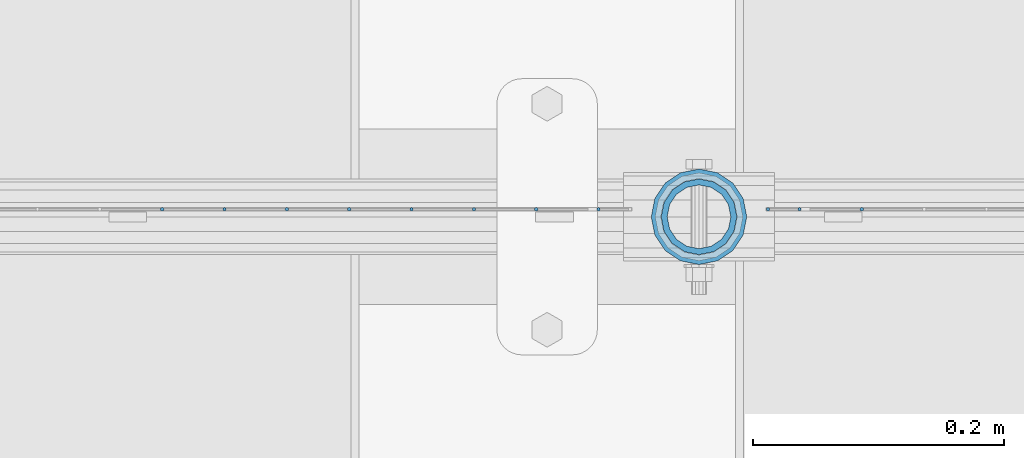
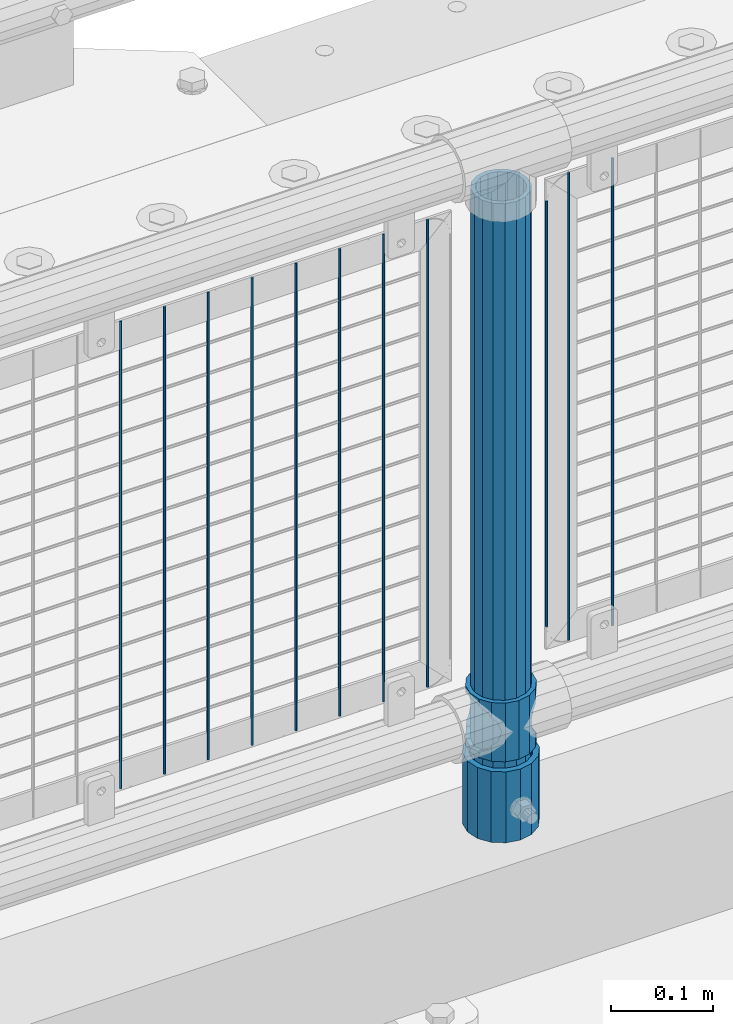
# One storey, part 74 of 247: 14 columns.
"""IFC2X3 building model written with IfcOpenShell, lengths in millimetres."""

from ifc_helpers import new_model, si_unit, frame, origin_with_axes, place, context, subcontext, project, spatial, faceted_brep, material, type_object, element, save


model = new_model("IFC2X3")

# Units and contexts
model_context = context("Model", 3, precision=1e-05, world=origin_with_axes())
body_context = subcontext(model_context, "Body", "Model", "MODEL_VIEW")
ifc_project = project(units=[si_unit("LENGTHUNIT", "METRE", prefix="MILLI"), si_unit("AREAUNIT", "SQUARE_METRE"), si_unit("VOLUMEUNIT", "CUBIC_METRE"), si_unit("MASSUNIT", "GRAM", prefix="KILO"), si_unit("TIMEUNIT", "SECOND"), si_unit("PLANEANGLEUNIT", "RADIAN"), si_unit("SOLIDANGLEUNIT", "STERADIAN"), si_unit("THERMODYNAMICTEMPERATUREUNIT", "DEGREE_CELSIUS"), si_unit("LUMINOUSINTENSITYUNIT", "LUMEN")], contexts=[model_context])

# Site, building, storey
site_placement = place(None, origin_with_axes())
site = spatial("IfcSite", under=ifc_project, at=site_placement, CompositionType="ELEMENT")
building_placement = place(site_placement, origin_with_axes())
building = spatial("IfcBuilding", under=site, at=building_placement, Name="Standard", CompositionType="ELEMENT")
storey_placement = place(building_placement, origin_with_axes())
storey = spatial("IfcBuildingStorey", under=building, at=storey_placement, Name="Undefined", CompositionType="ELEMENT", Elevation=0.0)

# Columns
ifc_material_1 = material()
column_type_1 = type_object("IfcColumnType", PredefinedType="NOTDEFINED")
column_1_placement = place(storey_placement, frame((3821.0, 7664.5, 168.02), z_axis=(0.0, 1.0, 0.0), x_axis=(0.0, 0.0, 1.0)))
element("IfcColumn", 1, at=column_1_placement, inside=storey, type_object=column_type_1, material=ifc_material_1, context=body_context, shape_type="Brep", body=[
    faceted_brep([(0.0, -31.75, 0.0), (0.0, -29.3331751572332, 12.1501989775916), (85.0, -29.3331751572332, 12.1501989775916), (85.0, -31.75, 0.0), (0.0, -22.4506403026735, 22.4506403026726), (85.0, -22.4506403026735, 22.4506403026726), (0.0, -12.1501989775916, 29.3331751572332), (85.0, -12.1501989775916, 29.3331751572332), (0.0, 0.0, 31.75), (85.0, 0.0, 31.75), (0.0, 12.1501989775916, 29.3331751572332), (85.0, 12.1501989775916, 29.3331751572332), (0.0, 22.4506403026735, 22.4506403026726), (85.0, 22.4506403026735, 22.4506403026726), (0.0, 29.3331751572332, 12.1501989775916), (85.0, 29.3331751572332, 12.1501989775916), (0.0, 31.75, 0.0), (85.0, 31.75, 0.0), (0.0, 29.3331751572332, -12.1501989775916), (85.0, 29.3331751572332, -12.1501989775916), (0.0, 22.4506403026735, -22.4506403026726), (85.0, 22.4506403026735, -22.4506403026726), (0.0, 12.1501989775916, -29.3331751572332), (85.0, 12.1501989775916, -29.3331751572332), (0.0, 0.0, -31.75), (85.0, 0.0, -31.75), (0.0, -12.1501989775916, -29.3331751572332), (85.0, -12.1501989775916, -29.3331751572332), (0.0, -22.4506403026735, -22.4506403026726), (85.0, -22.4506403026735, -22.4506403026726), (0.0, -29.3331751572332, -12.1501989775916), (85.0, -29.3331751572332, -12.1501989775916), (0.0, -38.0499999999993, 0.0), (0.0, -35.1536162120537, -14.5611046014919), (85.0, -35.1536162120537, -14.5611046014919), (85.0, -38.0499999999993, 0.0), (0.0, -26.9054130241475, -26.9054130241484), (85.0, -26.9054130241475, -26.9054130241484), (0.0, -14.561104601491, -35.1536162120547), (85.0, -14.561104601491, -35.1536162120547), (0.0, 0.0, -38.0500000000002), (85.0, 0.0, -38.0500000000002), (0.0, 14.561104601491, -35.1536162120547), (85.0, 14.561104601491, -35.1536162120547), (0.0, 26.9054130241475, -26.9054130241484), (85.0, 26.9054130241475, -26.9054130241484), (0.0, 35.1536162120537, -14.5611046014919), (85.0, 35.1536162120537, -14.5611046014919), (0.0, 38.0499999999993, 0.0), (85.0, 38.0499999999993, 0.0), (0.0, 35.1536162120537, 14.5611046014919), (85.0, 35.1536162120537, 14.5611046014919), (0.0, 26.9054130241475, 26.9054130241484), (85.0, 26.9054130241475, 26.9054130241484), (0.0, 14.561104601491, 35.1536162120547), (85.0, 14.561104601491, 35.1536162120547), (0.0, 0.0, 38.0500000000002), (85.0, 0.0, 38.0500000000002), (0.0, -14.561104601491, 35.1536162120547), (85.0, -14.561104601491, 35.1536162120547), (0.0, -26.9054130241475, 26.9054130241484), (85.0, -26.9054130241475, 26.9054130241484), (0.0, -35.1536162120537, 14.5611046014919), (85.0, -35.1536162120537, 14.5611046014919)], [[[0, 1, 2, 3]], [[1, 4, 5, 2]], [[4, 6, 7, 5]], [[6, 8, 9, 7]], [[8, 10, 11, 9]], [[10, 12, 13, 11]], [[12, 14, 15, 13]], [[14, 16, 17, 15]], [[16, 18, 19, 17]], [[18, 20, 21, 19]], [[20, 22, 23, 21]], [[22, 24, 25, 23]], [[24, 26, 27, 25]], [[26, 28, 29, 27]], [[28, 30, 31, 29]], [[30, 0, 3, 31]], [[32, 33, 34, 35]], [[33, 36, 37, 34]], [[36, 38, 39, 37]], [[38, 40, 41, 39]], [[40, 42, 43, 41]], [[42, 44, 45, 43]], [[44, 46, 47, 45]], [[46, 48, 49, 47]], [[48, 50, 51, 49]], [[50, 52, 53, 51]], [[52, 54, 55, 53]], [[54, 56, 57, 55]], [[56, 58, 59, 57]], [[58, 60, 61, 59]], [[60, 62, 63, 61]], [[62, 32, 35, 63]], [[37, 39, 41, 43, 45, 47, 49, 51, 53, 55, 57, 59, 61, 63, 35, 34], [5, 7, 9, 11, 13, 15, 17, 19, 21, 23, 25, 27, 29, 31, 3, 2]], [[62, 60, 58, 56, 54, 52, 50, 48, 46, 44, 42, 40, 38, 36, 33, 32], [30, 28, 26, 24, 22, 20, 18, 16, 14, 12, 10, 8, 6, 4, 1, 0]]]),
])
ifc_material_2 = material(Name="Misc_Undefined")
column_type_2 = type_object("IfcColumnType", PredefinedType="NOTDEFINED")
column_2_placement = place(storey_placement, frame((3821.0, 7664.5, 263.02), z_axis=(-1.0, 0.0, 0.0), x_axis=(0.0, 0.0, 1.0)))
element("IfcColumn", 2, at=column_2_placement, inside=storey, type_object=column_type_2, material=ifc_material_2, context=body_context, shape_type="Brep", body=[
    faceted_brep([(56.6106908090114, 21.4606908090118, -21.4606908090118), (56.6106908090114, 21.4606908090118, -27.1226768591096), (61.9623795176755, 13.4513226476329, -32.4743655677721), (63.1897438117172, 11.6144421722802, -32.839743811719), (63.1897438117172, 11.6144421722802, -28.0397438117179), (46.7644421722801, 28.0397438117179, -11.6144421722802), (46.7644421722801, 28.0397438117179, -20.088203122983), (51.5310424080055, 24.8548033587067, -24.8548033587067), (35.1499999999996, 30.35, 0.0), (35.1499999999996, 30.3500000000004, -16.6306603983649), (23.5355578277192, 28.0397438117179, -11.6144421722802), (23.5355578277192, 28.0397438117179, -20.088203122983), (13.6893091909879, 21.4606908090118, -21.4606908090118), (13.6893091909879, 21.4606908090118, -27.1226768591096), (18.768957591997, 24.8548033587067, -24.8548033587067), (7.11025618828211, 11.6144421722802, -28.0397438117179), (7.11025618828211, 11.6144421722802, -32.839743811719), (8.33762048232387, 13.4513226476329, -32.4743655677721), (4.79999999999961, 0.0, -30.3500000000004), (4.79999999999961, 0.0, -35.1499999999996), (7.11025618828211, -11.6144421722802, -28.0397438117179), (7.11025618828211, -11.6144421722802, -32.839743811719), (13.6893091909879, -21.4606908090118, -21.4606908090118), (13.6893091909879, -21.4606908090118, -27.1226768591077), (8.33762048232325, -13.4513226476329, -32.4743655677721), (23.5355578277191, -28.0397438117179, -11.6144421722802), (23.5355578277191, -28.0397438117179, -20.0882031229885), (18.768957591997, -24.8548033587067, -24.8548033587067), (35.1499999999996, -30.35, 0.0), (35.1499999999996, -30.3500000000004, -16.6306603983739), (46.7644421722801, -28.0397438117179, -11.6144421722802), (46.7644421722801, -28.0397438117179, -20.0882031229885), (56.6106908090114, -21.4606908090118, -21.4606908090118), (56.6106908090114, -21.4606908090118, -27.1226768591077), (51.5310424080038, -24.8548033587067, -24.8548033587067), (63.1897438117172, -11.6144421722802, -28.0397438117179), (63.1897438117172, -11.6144421722802, -32.839743811719), (61.9623795176754, -13.4513226476329, -32.4743655677721), (65.4999999999997, 0.0, -30.3500000000004), (65.4999999999997, 0.0, -35.1499999999996), (0.0, -28.0397438117179, -11.6144421722802), (0.0, -30.3500000000004, 0.0), (0.0, -21.4606908090118, -21.4606908090118), (0.0, -11.6144421722802, -28.0397438117179), (0.0, 0.0, -30.3500000000004), (0.0, 11.6144421722802, -28.0397438117179), (0.0, 21.4606908090118, -21.4606908090118), (0.0, 28.0397438117179, -11.6144421722802), (0.0, 30.3500000000004, 0.0), (0.0, 28.0397438117179, 11.6144421722802), (23.5355578277192, 28.0397438117179, 11.6144421722806), (0.0, 21.4606908090118, 21.4606908090118), (13.6893091909879, 21.4606908090118, 21.4606908090118), (0.0, 11.6144421722802, 28.0397438117179), (7.11025618828211, 11.6144421722802, 28.0397438117175), (0.0, 0.0, 30.3500000000004), (4.79999999999961, 0.0, 30.3499999999999), (0.0, -11.6144421722802, 28.0397438117179), (7.11025618828205, -11.6144421722802, 28.0397438117175), (0.0, -21.4606908090118, 21.4606908090118), (13.6893091909879, -21.4606908090118, 21.4606908090118), (0.0, -28.0397438117179, 11.6144421722802), (23.5355578277191, -28.0397438117179, 11.6144421722806), (0.0, -32.4743655677721, 13.4513226476338), (0.0, -35.1499999999996, 0.0), (70.2999999999993, -35.1499999999996, 0.0), (70.2999999999993, -32.4743655677721, 13.4513226476338), (0.0, 13.4513226476329, -32.4743655677721), (0.0, 24.8548033587067, -24.8548033587067), (0.0, 0.0, -35.1499999999996), (0.0, -13.4513226476329, -32.4743655677721), (0.0, -24.8548033587067, -24.8548033587067), (0.0, -24.8548033587067, 24.8548033587067), (0.0, -13.4513226476329, 32.4743655677721), (0.0, 0.0, 35.1499999999996), (0.0, 13.4513226476329, 32.4743655677721), (0.0, 24.8548033587067, 24.8548033587067), (0.0, 32.4743655677721, 13.4513226476338), (0.0, 35.1499999999996, 0.0), (0.0, 32.4743655677721, -13.4513226476338), (0.0, -32.4743655677721, -13.4513226476338), (70.2999999999993, 32.4743655677721, 13.4513226476338), (70.2999999999993, 35.1499999999996, 0.0), (70.2999999999993, 32.4743655677721, -13.4513226476338), (70.2999999999993, 24.8548033587067, -24.8548033587067), (70.2999999999993, 13.4513226476329, -32.4743655677721), (70.2999999999993, 0.0, -35.1499999999996), (70.2999999999993, -13.4513226476329, -32.4743655677721), (70.2999999999993, -24.8548033587067, -24.8548033587067), (70.2999999999993, -32.4743655677721, -13.4513226476338), (70.2999999999993, 28.0397438117179, 11.6144421722802), (70.2999999999993, 21.4606908090118, 21.4606908090118), (56.6106908090114, 21.4606908090118, 21.4606908090118), (46.7644421722801, 28.0397438117179, 11.6144421722806), (70.2999999999993, 11.6144421722802, 28.0397438117179), (63.1897438117172, 11.6144421722802, 28.0397438117175), (70.2999999999993, 0.0, 30.3500000000004), (65.4999999999997, 0.0, 30.3499999999999), (70.2999999999993, -11.6144421722802, 28.0397438117179), (63.1897438117172, -11.6144421722802, 28.0397438117175), (70.2999999999993, -21.4606908090118, 21.4606908090118), (56.6106908090114, -21.4606908090118, 21.4606908090118), (70.2999999999993, -28.0397438117179, 11.6144421722802), (46.7644421722801, -28.0397438117179, 11.6144421722806), (70.2999999999993, -11.6144421722802, -28.0397438117179), (70.2999999999993, 0.0, -30.3500000000004), (70.2999999999993, -21.4606908090118, -21.4606908090118), (70.2999999999993, -28.0397438117179, -11.6144421722802), (70.2999999999993, -30.3500000000004, 0.0), (70.2999999999993, 24.8548033587067, 24.8548033587067), (70.2999999999993, 13.4513226476329, 32.4743655677721), (70.2999999999993, 0.0, 35.1499999999996), (70.2999999999993, -13.4513226476329, 32.4743655677721), (70.2999999999993, -24.8548033587067, 24.8548033587067), (70.2999999999993, 30.3500000000004, 0.0), (70.2999999999993, 28.0397438117179, -11.6144421722802), (70.2999999999993, 21.4606908090118, -21.4606908090118), (70.2999999999993, 11.6144421722802, -28.0397438117179), (61.9623795176755, 13.4513226476329, 32.4743655677717), (51.5310424080043, 24.8548033587067, 24.8548033587072), (56.6106908090114, 21.4606908090118, 27.1226768591082), (65.4999999999997, 0.0, 35.1500000000001), (63.1897438117172, 11.6144421722802, 32.8397438117177), (63.1897438117172, -11.6144421722802, 32.8397438117177), (61.962379517675, -13.4513226476329, 32.4743655677717), (56.6106908090114, -21.4606908090118, 27.1226768591068), (51.5310424080026, -24.8548033587067, 24.8548033587072), (18.7689575919956, -24.8548033587067, 24.8548033587072), (46.7644421722801, -28.0397438117179, 20.088203122983), (35.1499999999996, -30.3500000000004, 16.6306603983649), (23.5355578277191, -28.0397438117179, 20.088203122983), (8.33762048232268, -13.4513226476329, 32.4743655677717), (13.6893091909879, -21.4606908090118, 27.1226768591068), (4.79999999999961, 0.0, 35.1500000000001), (7.11025618828205, -11.6144421722802, 32.8397438117177), (7.11025618828211, 11.6144421722802, 32.8397438117177), (8.33762048232427, 13.4513226476329, 32.4743655677717), (13.6893091909879, 21.4606908090118, 27.1226768591082), (18.7689575919966, 24.8548033587067, 24.8548033587072), (23.5355578277192, 28.0397438117179, 20.0882031229844), (35.1499999999996, 30.3500000000004, 16.6306603983667), (46.7644421722801, 28.0397438117179, 20.0882031229844)], [[[0, 1, 2, 3, 4]], [[5, 6, 7, 1, 0]], [[8, 9, 6, 5]], [[10, 11, 9, 8]], [[12, 13, 14, 11, 10]], [[15, 16, 17, 13, 12]], [[18, 19, 16, 15]], [[20, 21, 19, 18]], [[22, 23, 24, 21, 20]], [[25, 26, 27, 23, 22]], [[28, 29, 26, 25]], [[30, 31, 29, 28]], [[32, 33, 34, 31, 30]], [[35, 36, 37, 33, 32]], [[38, 39, 36, 35]], [[4, 3, 39, 38]], [[40, 41, 28, 25]], [[42, 40, 25, 22]], [[43, 42, 22, 20]], [[44, 43, 20, 18]], [[45, 44, 18, 15]], [[46, 45, 15, 12]], [[47, 46, 12, 10]], [[48, 47, 10, 8]], [[49, 48, 8, 50]], [[51, 49, 50, 52]], [[53, 51, 52, 54]], [[55, 53, 54, 56]], [[57, 55, 56, 58]], [[59, 57, 58, 60]], [[61, 59, 60, 62]], [[41, 61, 62, 28]], [[63, 64, 65, 66]], [[17, 67, 68, 14, 13]], [[19, 69, 67, 17, 16]], [[70, 69, 19, 21, 24]], [[71, 70, 24, 23, 27]], [[63, 72, 73, 74, 75, 76, 77, 78, 79, 68, 67, 69, 70, 71, 80, 64], [40, 42, 43, 44, 45, 46, 47, 48, 49, 51, 53, 55, 57, 59, 61, 41]], [[78, 77, 81, 82]], [[79, 78, 82, 83]], [[14, 68, 79, 83, 84, 7, 6, 9, 11]], [[84, 85, 2, 1, 7]], [[85, 86, 39, 3, 2]], [[37, 87, 88, 34, 33]], [[39, 86, 87, 37, 36]], [[34, 88, 89, 80, 71, 27, 26, 29, 31]], [[64, 80, 89, 65]], [[90, 91, 92, 93]], [[91, 94, 95, 92]], [[94, 96, 97, 95]], [[96, 98, 99, 97]], [[98, 100, 101, 99]], [[100, 102, 103, 101]], [[104, 105, 38, 35]], [[106, 104, 35, 32]], [[107, 106, 32, 30]], [[108, 107, 30, 28]], [[102, 108, 28, 103]], [[88, 87, 86, 85, 84, 83, 82, 81, 109, 110, 111, 112, 113, 66, 65, 89], [100, 98, 96, 94, 91, 90, 114, 115, 116, 117, 105, 104, 106, 107, 108, 102]], [[118, 110, 109, 119, 120]], [[121, 111, 110, 118, 122]], [[112, 111, 121, 123, 124]], [[113, 112, 124, 125, 126]], [[127, 72, 63, 66, 113, 126, 128, 129, 130]], [[131, 73, 72, 127, 132]], [[133, 74, 73, 131, 134]], [[75, 74, 133, 135, 136]], [[76, 75, 136, 137, 138]], [[119, 109, 81, 77, 76, 138, 139, 140, 141]], [[92, 120, 119, 141, 93]], [[95, 122, 118, 120, 92]], [[97, 121, 122, 95]], [[99, 123, 121, 97]], [[101, 125, 124, 123, 99]], [[103, 128, 126, 125, 101]], [[28, 129, 128, 103]], [[62, 130, 129, 28]], [[60, 132, 127, 130, 62]], [[58, 134, 131, 132, 60]], [[56, 133, 134, 58]], [[54, 135, 133, 56]], [[52, 137, 136, 135, 54]], [[50, 139, 138, 137, 52]], [[8, 140, 139, 50]], [[93, 141, 140, 8]], [[114, 90, 93, 8]], [[115, 114, 8, 5]], [[116, 115, 5, 0]], [[117, 116, 0, 4]], [[105, 117, 4, 38]]]),
])
column_type_3 = type_object("IfcColumnType", PredefinedType="NOTDEFINED")
column_3_placement = place(storey_placement, frame((3821.0, 7664.5, 168.02), z_axis=(-1.0, 0.0, 0.0), x_axis=(0.0, 0.0, 1.0)))
element("IfcColumn", 3, at=column_3_placement, inside=storey, type_object=column_type_3, material=ifc_material_1, context=body_context, shape_type="Brep", body=[
    faceted_brep([(0.0, -25.3500000000004, 0.0), (0.0, -23.4203461491616, 9.70102501045585), (760.0, -23.4203461491616, 9.70102501045585), (760.0, -25.3500000000004, 0.0), (0.0, -17.9251569030794, 17.9251569030785), (760.0, -17.9251569030794, 17.9251569030785), (0.0, -9.70102501045494, 23.4203461491616), (760.0, -9.70102501045494, 23.4203461491616), (0.0, 0.0, 25.3500000000004), (760.0, 0.0, 25.3500000000004), (0.0, 9.70102501045494, 23.4203461491616), (760.0, 9.70102501045494, 23.4203461491616), (0.0, 17.9251569030794, 17.9251569030785), (760.0, 17.9251569030794, 17.9251569030785), (0.0, 23.4203461491616, 9.70102501045585), (760.0, 23.4203461491616, 9.70102501045585), (0.0, 25.3500000000004, 0.0), (760.0, 25.3500000000004, 0.0), (0.0, 23.4203461491616, -9.70102501045585), (760.0, 23.4203461491616, -9.70102501045585), (0.0, 17.9251569030794, -17.9251569030785), (760.0, 17.9251569030794, -17.9251569030785), (0.0, 9.70102501045494, -23.4203461491616), (760.0, 9.70102501045494, -23.4203461491616), (0.0, 0.0, -25.3500000000004), (760.0, 0.0, -25.3500000000004), (0.0, -9.70102501045494, -23.4203461491616), (760.0, -9.70102501045494, -23.4203461491616), (0.0, -17.9251569030794, -17.9251569030785), (760.0, -17.9251569030794, -17.9251569030785), (0.0, -23.4203461491616, -9.70102501045585), (760.0, -23.4203461491616, -9.70102501045585), (0.0, -30.1499999999996, 0.0), (0.0, -27.8549679052148, -11.5379054858076), (760.0, -27.8549679052148, -11.5379054858076), (760.0, -30.1499999999996, 0.0), (0.0, -21.3192694527743, -21.3192694527752), (760.0, -21.3192694527743, -21.3192694527752), (0.0, -11.5379054858076, -27.8549679052157), (760.0, -11.5379054858076, -27.8549679052157), (0.0, 0.0, -30.1499999999996), (760.0, 0.0, -30.1499999999996), (0.0, 11.5379054858076, -27.8549679052157), (760.0, 11.5379054858076, -27.8549679052157), (0.0, 21.3192694527743, -21.3192694527752), (760.0, 21.3192694527743, -21.3192694527752), (0.0, 27.8549679052157, -11.5379054858076), (760.0, 27.8549679052157, -11.5379054858076), (0.0, 30.1499999999996, 0.0), (760.0, 30.1499999999996, 0.0), (0.0, 27.8549679052157, 11.5379054858076), (760.0, 27.8549679052157, 11.5379054858076), (0.0, 21.3192694527743, 21.3192694527752), (760.0, 21.3192694527743, 21.3192694527752), (0.0, 11.5379054858076, 27.8549679052157), (760.0, 11.5379054858076, 27.8549679052157), (0.0, 0.0, 30.1499999999996), (760.0, 0.0, 30.1499999999996), (0.0, -11.5379054858076, 27.8549679052157), (760.0, -11.5379054858076, 27.8549679052157), (0.0, -21.3192694527743, 21.3192694527752), (760.0, -21.3192694527743, 21.3192694527752), (0.0, -27.8549679052157, 11.5379054858076), (760.0, -27.8549679052157, 11.5379054858076)], [[[0, 1, 2, 3]], [[1, 4, 5, 2]], [[4, 6, 7, 5]], [[6, 8, 9, 7]], [[8, 10, 11, 9]], [[10, 12, 13, 11]], [[12, 14, 15, 13]], [[14, 16, 17, 15]], [[16, 18, 19, 17]], [[18, 20, 21, 19]], [[20, 22, 23, 21]], [[22, 24, 25, 23]], [[24, 26, 27, 25]], [[26, 28, 29, 27]], [[28, 30, 31, 29]], [[30, 0, 3, 31]], [[32, 33, 34, 35]], [[33, 36, 37, 34]], [[36, 38, 39, 37]], [[38, 40, 41, 39]], [[40, 42, 43, 41]], [[42, 44, 45, 43]], [[44, 46, 47, 45]], [[46, 48, 49, 47]], [[48, 50, 51, 49]], [[50, 52, 53, 51]], [[52, 54, 55, 53]], [[54, 56, 57, 55]], [[56, 58, 59, 57]], [[58, 60, 61, 59]], [[60, 62, 63, 61]], [[62, 32, 35, 63]], [[37, 39, 41, 43, 45, 47, 49, 51, 53, 55, 57, 59, 61, 63, 35, 34], [5, 7, 9, 11, 13, 15, 17, 19, 21, 23, 25, 27, 29, 31, 3, 2]], [[62, 60, 58, 56, 54, 52, 50, 48, 46, 44, 42, 40, 38, 36, 33, 32], [30, 28, 26, 24, 22, 20, 18, 16, 14, 12, 10, 8, 6, 4, 1, 0]]]),
])
column_type_4 = type_object("IfcColumnType", Name="D3", PredefinedType="NOTDEFINED")
column_4_placement = place(storey_placement, frame((3950.65517241379, 7670.5, 353.02), z_axis=(-0.999999999962839, 0.0, 8.62099999968473e-06), x_axis=(8.62099999949798e-06, 0.0, 0.999999999962839)))
element("IfcColumn", 4, at=column_4_placement, inside=storey, type_object=column_type_4, material=ifc_material_2, ObjectType="D3", context=body_context, shape_type="Brep", body=[
    faceted_brep([(1.81898940354586e-12, -1.5, -5.6843418860808e-14), (0.0, -0.75, -1.29903810567703), (560.0, -0.75, -1.29903810567703), (560.0, -1.5, 0.0), (0.0, 0.75, -1.29903810567703), (560.0, 0.75, -1.29903810567703), (1.81898940354586e-12, 1.5, -5.6843418860808e-14), (560.0, 1.5, 0.0), (0.0, 0.75, 1.29903810567703), (560.0, 0.75, 1.29903810567703), (0.0, -0.75, 1.29903810567703), (560.0, -0.75, 1.29903810567703)], [[[0, 1, 2, 3]], [[1, 4, 5, 2]], [[4, 6, 7, 5]], [[6, 8, 9, 7]], [[8, 10, 11, 9]], [[10, 0, 3, 11]], [[5, 7, 9, 11, 3, 2]], [[10, 8, 6, 4, 1, 0]]]),
])
column_5_placement = place(storey_placement, frame((3876.0, 7670.5, 378.02), z_axis=(-1.0, 0.0, 0.0), x_axis=(0.0, 0.0, 1.0)))
element("IfcColumn", 5, at=column_5_placement, inside=storey, type_object=column_type_4, material=ifc_material_2, ObjectType="D3", context=body_context, shape_type="Brep", body=[
    faceted_brep([(1.81898940354586e-12, -1.5, -5.6843418860808e-14), (0.0, -0.75, -1.29903810567703), (510.0, -0.75, -1.29903810567703), (510.0, -1.5, 0.0), (0.0, 0.75, -1.29903810567703), (510.0, 0.75, -1.29903810567703), (1.81898940354586e-12, 1.5, -5.6843418860808e-14), (510.0, 1.5, 0.0), (0.0, 0.75, 1.29903810567703), (510.0, 0.75, 1.29903810567703), (0.0, -0.75, 1.29903810567703), (510.0, -0.75, 1.29903810567703)], [[[0, 1, 2, 3]], [[1, 4, 5, 2]], [[4, 6, 7, 5]], [[6, 8, 9, 7]], [[8, 10, 11, 9]], [[10, 0, 3, 11]], [[5, 7, 9, 11, 3, 2]], [[10, 8, 6, 4, 1, 0]]]),
])
for number, where, z_axis, x_axis in (
    (6, (3901.0, 7670.5, 353.02), (-1.0, 0.0, 0.0), (0.0, 0.0, 1.0)),
    (7, (3740.995, 7670.5, 353.02), (-1.0, 0.0, 0.0), (0.0, 0.0, 1.0)),
    (8, (3691.34, 7670.5, 353.02), (-1.0, 0.0, 0.0), (0.0, 0.0, 1.0)),
    (9, (3641.685, 7670.5, 353.02), (-1.0, 0.0, 0.0), (0.0, 0.0, 1.0)),
    (10, (3592.03, 7670.5, 353.02), (-1.0, 0.0, 0.0), (0.0, 0.0, 1.0)),
    (11, (3542.375, 7670.5, 353.02), (-1.0, 0.0, 0.0), (0.0, 0.0, 1.0)),
    (12, (3492.72, 7670.5, 353.02), (-1.0, 0.0, 0.0), (0.0, 0.0, 1.0)),
    (13, (3443.065, 7670.5, 353.02), (-1.0, 0.0, 0.0), (0.0, 0.0, 1.0)),
    (14, (3393.41, 7670.5, 353.02), (-1.0, 0.0, 0.0), (0.0, 0.0, 1.0)),
):
    element("IfcColumn", number, at=place(storey_placement, frame(where, z_axis=z_axis, x_axis=x_axis)), inside=storey, type_object=column_type_4, material=ifc_material_2, ObjectType="D3", context=body_context, shape_type="Brep", body=[
        faceted_brep([(1.81898940354586e-12, -1.5, -5.6843418860808e-14), (0.0, -0.75, -1.29903810567703), (560.0, -0.75, -1.29903810567703), (560.0, -1.5, 0.0), (0.0, 0.75, -1.29903810567703), (560.0, 0.75, -1.29903810567703), (1.81898940354586e-12, 1.5, -5.6843418860808e-14), (560.0, 1.5, 0.0), (0.0, 0.75, 1.29903810567703), (560.0, 0.75, 1.29903810567703), (0.0, -0.75, 1.29903810567703), (560.0, -0.75, 1.29903810567703)], [[[0, 1, 2, 3]], [[1, 4, 5, 2]], [[4, 6, 7, 5]], [[6, 8, 9, 7]], [[8, 10, 11, 9]], [[10, 0, 3, 11]], [[5, 7, 9, 11, 3, 2]], [[10, 8, 6, 4, 1, 0]]]),
    ])

save(model, "model.ifc")
